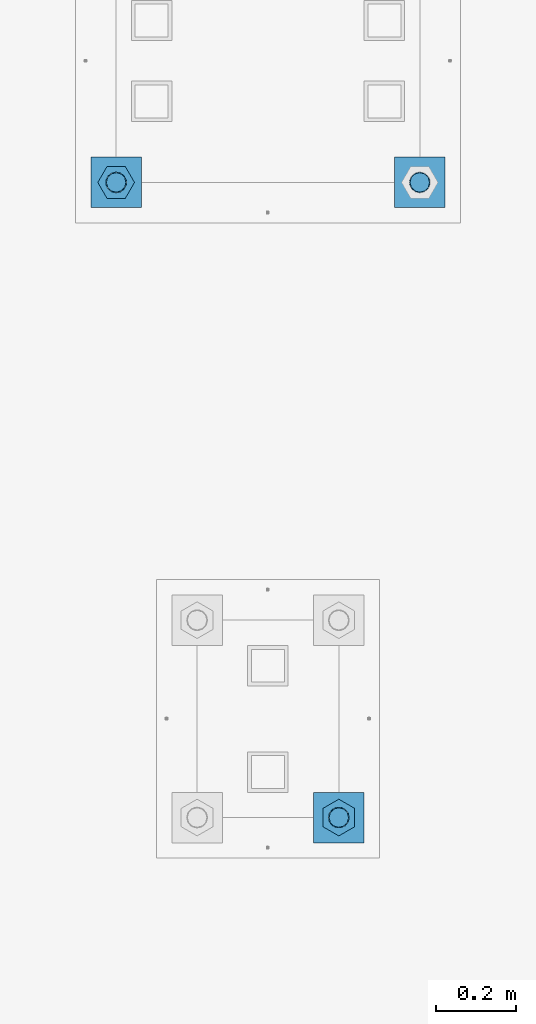
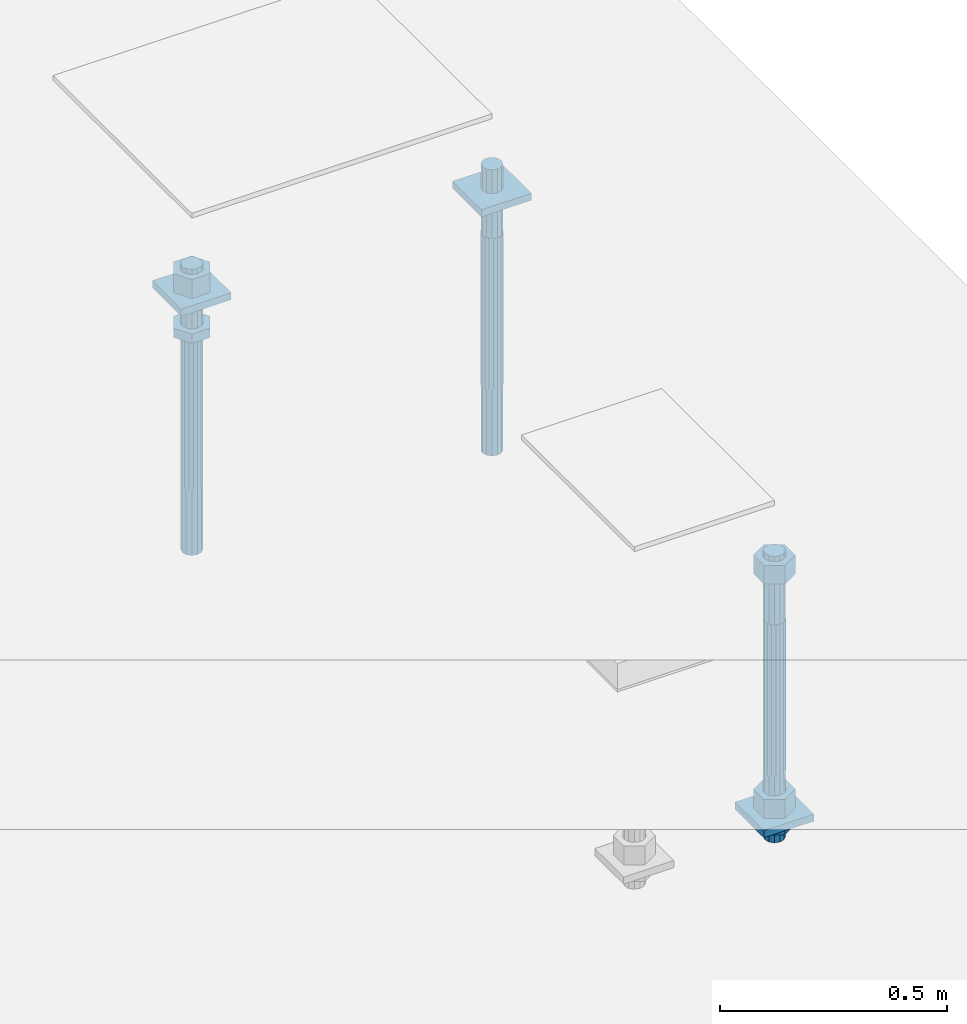
# One storey, part 2631 of 3843: 11 beams, 2 elements without a shape of their own.
"""IFC2X3 building model written with IfcOpenShell, lengths in millimetres."""

from ifc_helpers import new_model, si_unit, frame, origin_with_axes, place, context, subcontext, project, spatial, faceted_brep, material, type_object, element, aggregate, save


model = new_model("IFC2X3")

# Units and contexts
model_context = context("Model", 3, precision=1e-05, world=origin_with_axes())
body_context = subcontext(model_context, "Body", "Model", "MODEL_VIEW")
ifc_project = project(units=[si_unit("LENGTHUNIT", "METRE", prefix="MILLI"), si_unit("AREAUNIT", "SQUARE_METRE"), si_unit("VOLUMEUNIT", "CUBIC_METRE"), si_unit("MASSUNIT", "GRAM", prefix="KILO"), si_unit("TIMEUNIT", "SECOND"), si_unit("PLANEANGLEUNIT", "RADIAN"), si_unit("SOLIDANGLEUNIT", "STERADIAN"), si_unit("THERMODYNAMICTEMPERATUREUNIT", "DEGREE_CELSIUS"), si_unit("LUMINOUSINTENSITYUNIT", "LUMEN")], contexts=[model_context])

# Site, building, storey
site_placement = place(None, origin_with_axes())
site = spatial("IfcSite", under=ifc_project, at=site_placement, CompositionType="ELEMENT")
building_placement = place(site_placement, origin_with_axes())
building = spatial("IfcBuilding", under=site, at=building_placement, Name="Undefined", CompositionType="ELEMENT")
storey_placement = place(building_placement, origin_with_axes())
storey = spatial("IfcBuildingStorey", under=building, at=storey_placement, Name="Undefined", CompositionType="ELEMENT", Elevation=0.0)

# Assembly, beams
assembly_1_placement = place(storey_placement, origin_with_axes())
assembly_1 = element("IfcElementAssembly", 1, at=assembly_1_placement, inside=storey, Name="TEMPLATE", AssemblyPlace="NOTDEFINED", PredefinedType="RIGID_FRAME")
ifc_material_1 = material(Name="STEEL/A572-50")
beam_type_1 = type_object("IfcBeamType", PredefinedType="NOTDEFINED")
beam_1_placement = place(assembly_1_placement, frame((118465.6, 1282.70000152587, 29873.575), z_axis=(1.0, 0.0, 0.0), x_axis=(0.0, 1.0, 0.0)))
beam_1 = element("IfcBeam", 2, at=beam_1_placement, type_object=beam_type_1, material=ifc_material_1, Name="WASHER_PLATE", context=body_context, shape_type="Brep", body=[
    faceted_brep([(0.0, 9.52500000000146, -63.5), (0.0, 9.52500000000146, 63.5), (127.0, 9.52500000000146, 63.5), (127.0, 9.52500000000146, -63.5), (0.0, -9.52500000000146, 63.5), (127.0, -9.52500000000146, 63.5), (0.0, -9.52500000000146, -63.5), (127.0, -9.52500000000146, -63.5)], [[[0, 1, 2, 3]], [[1, 4, 5, 2]], [[4, 6, 7, 5]], [[6, 0, 3, 7]], [[5, 7, 3, 2]], [[6, 4, 1, 0]]]),
])
beam_2_placement = place(assembly_1_placement, frame((119227.6, 1282.70000152587, 29873.575), z_axis=(1.0, 0.0, 0.0), x_axis=(0.0, 1.0, 0.0)))
beam_2 = element("IfcBeam", 3, at=beam_2_placement, type_object=beam_type_1, material=ifc_material_1, Name="WASHER_PLATE", context=body_context, shape_type="Brep", body=[
    faceted_brep([(0.0, 9.52500000000146, -63.5), (0.0, 9.52500000000146, 63.5), (127.0, 9.52500000000146, 63.5), (127.0, 9.52500000000146, -63.5), (0.0, -9.52500000000146, 63.5), (127.0, -9.52500000000146, 63.5), (0.0, -9.52500000000146, -63.5), (127.0, -9.52500000000146, -63.5)], [[[0, 1, 2, 3]], [[1, 4, 5, 2]], [[4, 6, 7, 5]], [[6, 0, 3, 7]], [[5, 7, 3, 2]], [[6, 4, 1, 0]]]),
])

# Assembly, beam
assembly_2_placement = place(storey_placement, origin_with_axes())
assembly_2 = element("IfcElementAssembly", 4, at=assembly_2_placement, inside=storey, Name="TEMPLATE", AssemblyPlace="NOTDEFINED", PredefinedType="RIGID_FRAME")
beam_3_placement = place(assembly_2_placement, frame((118960.900001526, -247.649999999994, 29244.925), z_axis=(0.0, -1.0, 0.0), x_axis=(1.0, 0.0, 0.0)))
beam_3 = element("IfcBeam", 5, at=beam_3_placement, type_object=beam_type_1, material=ifc_material_1, Name="WASHER_PLATE", context=body_context, shape_type="Brep", body=[
    faceted_brep([(0.0, 9.52500000000146, -63.5), (0.0, 9.52500000000146, 63.5), (127.0, 9.52500000000146, 63.5), (127.0, 9.52500000000146, -63.5), (0.0, -9.52500000000146, 63.5), (127.0, -9.52500000000146, 63.5), (0.0, -9.52500000000146, -63.5), (127.0, -9.52500000000146, -63.5)], [[[0, 1, 2, 3]], [[1, 4, 5, 2]], [[4, 6, 7, 5]], [[6, 0, 3, 7]], [[5, 7, 3, 2]], [[6, 4, 1, 0]]]),
])

# Beam
ifc_material_2 = material(Name="STEEL/A36")
beam_type_2 = type_object("IfcBeamType", Name="2_HALF_NUT", PredefinedType="NOTDEFINED")
beam_4_placement = place(assembly_1_placement, frame((118465.6, 1346.20000152587, 29787.85), z_axis=(0.0, 1.0, 0.0), x_axis=(0.0, 0.0, -1.0)))
beam_4 = element("IfcBeam", 6, at=beam_4_placement, type_object=beam_type_2, material=ifc_material_2, Name="NUT", ObjectType="2_HALF_NUT", context=body_context, shape_type="Brep", body=[
    faceted_brep([(0.0, -46.0369987487793, 0.0), (0.0, -23.0184993743896, -39.869213104248), (25.4000000000015, -23.0184993743896, -39.869213104248), (25.4000000000015, -46.0369987487793, 0.0), (0.0, 23.0184993743896, -39.869213104248), (25.4000000000015, 23.0184993743896, -39.869213104248), (0.0, 46.0369987487793, 0.0), (25.4000000000015, 46.0369987487793, 0.0), (0.0, 23.0184993743896, 39.869213104248), (25.4000000000015, 23.0184993743896, 39.869213104248), (0.0, -23.0184993743896, 39.869213104248), (25.4000000000015, -23.0184993743896, 39.869213104248), (0.0, 0.0, 26.1940002441406), (0.0, 11.3650617044477, 23.5999013092805), (25.4000000000015, 11.3650617044477, 23.5999013092805), (25.4000000000015, 0.0, 26.1940002441406), (0.0, 20.4791109456419, 16.3316083006721), (25.4000000000015, 20.4791109456419, 16.3316083006721), (0.0, 25.5370200498292, 5.82867859874386), (25.4000000000015, 25.5370200498292, 5.82867859874386), (0.0, 25.5370200498292, -5.82867859874386), (25.4000000000015, 25.5370200498292, -5.82867859874386), (0.0, 20.4791109456419, -16.3316083006721), (25.4000000000015, 20.4791109456419, -16.3316083006721), (0.0, 11.3650617044477, -23.5999013092805), (25.4000000000015, 11.3650617044477, -23.5999013092805), (0.0, 0.0, -26.1940002441406), (25.4000000000015, 0.0, -26.1940002441406), (0.0, -11.3650617044477, -23.5999013092805), (25.4000000000015, -11.3650617044477, -23.5999013092805), (0.0, -20.4791109456419, -16.3316083006721), (25.4000000000015, -20.4791109456419, -16.3316083006721), (0.0, -25.5370200498292, -5.82867859874386), (25.4000000000015, -25.5370200498292, -5.82867859874386), (0.0, -25.5370200498292, 5.82867859874386), (25.4000000000015, -25.5370200498292, 5.82867859874386), (0.0, -20.4791109456419, 16.3316083006721), (25.4000000000015, -20.4791109456419, 16.3316083006721), (0.0, -11.3650617044477, 23.5999013092805), (25.4000000000015, -11.3650617044477, 23.5999013092805)], [[[0, 1, 2, 3]], [[1, 4, 5, 2]], [[4, 6, 7, 5]], [[6, 8, 9, 7]], [[8, 10, 11, 9]], [[10, 0, 3, 11]], [[12, 13, 14, 15]], [[13, 16, 17, 14]], [[16, 18, 19, 17]], [[18, 20, 21, 19]], [[20, 22, 23, 21]], [[22, 24, 25, 23]], [[24, 26, 27, 25]], [[26, 28, 29, 27]], [[28, 30, 31, 29]], [[30, 32, 33, 31]], [[32, 34, 35, 33]], [[34, 36, 37, 35]], [[36, 38, 39, 37]], [[38, 12, 15, 39]], [[5, 7, 9, 11, 3, 2], [17, 19, 21, 23, 25, 27, 29, 31, 33, 35, 37, 39, 15, 14]], [[10, 8, 6, 4, 1, 0], [38, 36, 34, 32, 30, 28, 26, 24, 22, 20, 18, 16, 13, 12]]]),
])

beam_5_placement = place(assembly_2_placement, frame((119024.400001526, -247.649999999994, 29235.4), z_axis=(1.0, 0.0, 0.0), x_axis=(0.0, 0.0, -1.0)))
beam_5 = element("IfcBeam", 7, at=beam_5_placement, type_object=beam_type_2, material=ifc_material_2, Name="NUT", ObjectType="2_HALF_NUT", context=body_context, shape_type="Brep", body=[
    faceted_brep([(0.0, -46.0369987487793, 0.0), (0.0, -23.0184993743896, -39.869213104248), (25.4000000000015, -23.0184993743896, -39.869213104248), (25.4000000000015, -46.0369987487793, 0.0), (0.0, 23.0184993743896, -39.869213104248), (25.4000000000015, 23.0184993743896, -39.869213104248), (0.0, 46.0369987487793, 0.0), (25.4000000000015, 46.0369987487793, 0.0), (0.0, 23.0184993743896, 39.869213104248), (25.4000000000015, 23.0184993743896, 39.869213104248), (0.0, -23.0184993743896, 39.869213104248), (25.4000000000015, -23.0184993743896, 39.869213104248), (0.0, 0.0, 26.1940002441406), (0.0, 11.3650617044477, 23.5999013092805), (25.4000000000015, 11.3650617044477, 23.5999013092805), (25.4000000000015, 0.0, 26.1940002441406), (0.0, 20.4791109456419, 16.3316083006721), (25.4000000000015, 20.4791109456419, 16.3316083006721), (0.0, 25.5370200498292, 5.82867859874386), (25.4000000000015, 25.5370200498292, 5.82867859874386), (0.0, 25.5370200498292, -5.82867859874386), (25.4000000000015, 25.5370200498292, -5.82867859874386), (0.0, 20.4791109456419, -16.3316083006721), (25.4000000000015, 20.4791109456419, -16.3316083006721), (0.0, 11.3650617044477, -23.5999013092805), (25.4000000000015, 11.3650617044477, -23.5999013092805), (0.0, 0.0, -26.1940002441406), (25.4000000000015, 0.0, -26.1940002441406), (0.0, -11.3650617044477, -23.5999013092805), (25.4000000000015, -11.3650617044477, -23.5999013092805), (0.0, -20.4791109456419, -16.3316083006721), (25.4000000000015, -20.4791109456419, -16.3316083006721), (0.0, -25.5370200498292, -5.82867859874386), (25.4000000000015, -25.5370200498292, -5.82867859874386), (0.0, -25.5370200498292, 5.82867859874386), (25.4000000000015, -25.5370200498292, 5.82867859874386), (0.0, -20.4791109456419, 16.3316083006721), (25.4000000000015, -20.4791109456419, 16.3316083006721), (0.0, -11.3650617044477, 23.5999013092805), (25.4000000000015, -11.3650617044477, 23.5999013092805)], [[[0, 1, 2, 3]], [[1, 4, 5, 2]], [[4, 6, 7, 5]], [[6, 8, 9, 7]], [[8, 10, 11, 9]], [[10, 0, 3, 11]], [[12, 13, 14, 15]], [[13, 16, 17, 14]], [[16, 18, 19, 17]], [[18, 20, 21, 19]], [[20, 22, 23, 21]], [[22, 24, 25, 23]], [[24, 26, 27, 25]], [[26, 28, 29, 27]], [[28, 30, 31, 29]], [[30, 32, 33, 31]], [[32, 34, 35, 33]], [[34, 36, 37, 35]], [[36, 38, 39, 37]], [[38, 12, 15, 39]], [[5, 7, 9, 11, 3, 2], [17, 19, 21, 23, 25, 27, 29, 31, 33, 35, 37, 39, 15, 14]], [[10, 8, 6, 4, 1, 0], [38, 36, 34, 32, 30, 28, 26, 24, 22, 20, 18, 16, 13, 12]]]),
])

beam_type_3 = type_object("IfcBeamType", Name="2_HEAVY_HEX_NUT", PredefinedType="NOTDEFINED")
beam_6_placement = place(assembly_1_placement, frame((118465.6, 1346.20000152587, 29933.9), z_axis=(0.0, 1.0, 0.0), x_axis=(0.0, 0.0, -1.0)))
beam_6 = element("IfcBeam", 8, at=beam_6_placement, type_object=beam_type_3, material=ifc_material_2, Name="NUT", ObjectType="2_HEAVY_HEX_NUT", context=body_context, shape_type="Brep", body=[
    faceted_brep([(0.0, -46.0369987487793, 0.0), (0.0, -23.0184993743896, -39.869213104248), (50.7999999999993, -23.0184993743896, -39.869213104248), (50.7999999999993, -46.0369987487793, 0.0), (0.0, 23.0184993743896, -39.869213104248), (50.7999999999993, 23.0184993743896, -39.869213104248), (0.0, 46.0369987487793, 0.0), (50.7999999999993, 46.0369987487793, 0.0), (0.0, 23.0184993743896, 39.869213104248), (50.7999999999993, 23.0184993743896, 39.869213104248), (0.0, -23.0184993743896, 39.869213104248), (50.7999999999993, -23.0184993743896, 39.869213104248), (0.0, 0.0, 26.1940002441406), (0.0, 11.3650617044477, 23.5999013092805), (50.7999999999993, 11.3650617044477, 23.5999013092805), (50.7999999999993, 0.0, 26.1940002441406), (0.0, 20.4791109456419, 16.3316083006721), (50.7999999999993, 20.4791109456419, 16.3316083006721), (0.0, 25.5370200498292, 5.82867859874386), (50.7999999999993, 25.5370200498292, 5.82867859874386), (0.0, 25.5370200498292, -5.82867859874386), (50.7999999999993, 25.5370200498292, -5.82867859874386), (0.0, 20.4791109456419, -16.3316083006721), (50.7999999999993, 20.4791109456419, -16.3316083006721), (0.0, 11.3650617044477, -23.5999013092805), (50.7999999999993, 11.3650617044477, -23.5999013092805), (0.0, 0.0, -26.1940002441406), (50.7999999999993, 0.0, -26.1940002441406), (0.0, -11.3650617044477, -23.5999013092805), (50.7999999999993, -11.3650617044477, -23.5999013092805), (0.0, -20.4791109456419, -16.3316083006721), (50.7999999999993, -20.4791109456419, -16.3316083006721), (0.0, -25.5370200498292, -5.82867859874386), (50.7999999999993, -25.5370200498292, -5.82867859874386), (0.0, -25.5370200498292, 5.82867859874386), (50.7999999999993, -25.5370200498292, 5.82867859874386), (0.0, -20.4791109456419, 16.3316083006721), (50.7999999999993, -20.4791109456419, 16.3316083006721), (0.0, -11.3650617044477, 23.5999013092805), (50.7999999999993, -11.3650617044477, 23.5999013092805)], [[[0, 1, 2, 3]], [[1, 4, 5, 2]], [[4, 6, 7, 5]], [[6, 8, 9, 7]], [[8, 10, 11, 9]], [[10, 0, 3, 11]], [[12, 13, 14, 15]], [[13, 16, 17, 14]], [[16, 18, 19, 17]], [[18, 20, 21, 19]], [[20, 22, 23, 21]], [[22, 24, 25, 23]], [[24, 26, 27, 25]], [[26, 28, 29, 27]], [[28, 30, 31, 29]], [[30, 32, 33, 31]], [[32, 34, 35, 33]], [[34, 36, 37, 35]], [[36, 38, 39, 37]], [[38, 12, 15, 39]], [[5, 7, 9, 11, 3, 2], [17, 19, 21, 23, 25, 27, 29, 31, 33, 35, 37, 39, 15, 14]], [[10, 8, 6, 4, 1, 0], [38, 36, 34, 32, 30, 28, 26, 24, 22, 20, 18, 16, 13, 12]]]),
])

beam_7_placement = place(assembly_2_placement, frame((119024.400001526, -247.649999999994, 29933.9), z_axis=(1.0, 0.0, 0.0), x_axis=(0.0, 0.0, -1.0)))
beam_7 = element("IfcBeam", 9, at=beam_7_placement, type_object=beam_type_3, material=ifc_material_2, Name="NUT", ObjectType="2_HEAVY_HEX_NUT", context=body_context, shape_type="Brep", body=[
    faceted_brep([(0.0, -46.0369987487793, 0.0), (0.0, -23.0184993743896, -39.869213104248), (50.7999999999993, -23.0184993743896, -39.869213104248), (50.7999999999993, -46.0369987487793, 0.0), (0.0, 23.0184993743896, -39.869213104248), (50.7999999999993, 23.0184993743896, -39.869213104248), (0.0, 46.0369987487793, 0.0), (50.7999999999993, 46.0369987487793, 0.0), (0.0, 23.0184993743896, 39.869213104248), (50.7999999999993, 23.0184993743896, 39.869213104248), (0.0, -23.0184993743896, 39.869213104248), (50.7999999999993, -23.0184993743896, 39.869213104248), (0.0, 0.0, 26.1940002441406), (0.0, 11.3650617044477, 23.5999013092805), (50.7999999999993, 11.3650617044477, 23.5999013092805), (50.7999999999993, 0.0, 26.1940002441406), (0.0, 20.4791109456419, 16.3316083006721), (50.7999999999993, 20.4791109456419, 16.3316083006721), (0.0, 25.5370200498292, 5.82867859874386), (50.7999999999993, 25.5370200498292, 5.82867859874386), (0.0, 25.5370200498292, -5.82867859874386), (50.7999999999993, 25.5370200498292, -5.82867859874386), (0.0, 20.4791109456419, -16.3316083006721), (50.7999999999993, 20.4791109456419, -16.3316083006721), (0.0, 11.3650617044477, -23.5999013092805), (50.7999999999993, 11.3650617044477, -23.5999013092805), (0.0, 0.0, -26.1940002441406), (50.7999999999993, 0.0, -26.1940002441406), (0.0, -11.3650617044477, -23.5999013092805), (50.7999999999993, -11.3650617044477, -23.5999013092805), (0.0, -20.4791109456419, -16.3316083006721), (50.7999999999993, -20.4791109456419, -16.3316083006721), (0.0, -25.5370200498292, -5.82867859874386), (50.7999999999993, -25.5370200498292, -5.82867859874386), (0.0, -25.5370200498292, 5.82867859874386), (50.7999999999993, -25.5370200498292, 5.82867859874386), (0.0, -20.4791109456419, 16.3316083006721), (50.7999999999993, -20.4791109456419, 16.3316083006721), (0.0, -11.3650617044477, 23.5999013092805), (50.7999999999993, -11.3650617044477, 23.5999013092805)], [[[0, 1, 2, 3]], [[1, 4, 5, 2]], [[4, 6, 7, 5]], [[6, 8, 9, 7]], [[8, 10, 11, 9]], [[10, 0, 3, 11]], [[12, 13, 14, 15]], [[13, 16, 17, 14]], [[16, 18, 19, 17]], [[18, 20, 21, 19]], [[20, 22, 23, 21]], [[22, 24, 25, 23]], [[24, 26, 27, 25]], [[26, 28, 29, 27]], [[28, 30, 31, 29]], [[30, 32, 33, 31]], [[32, 34, 35, 33]], [[34, 36, 37, 35]], [[36, 38, 39, 37]], [[38, 12, 15, 39]], [[5, 7, 9, 11, 3, 2], [17, 19, 21, 23, 25, 27, 29, 31, 33, 35, 37, 39, 15, 14]], [[10, 8, 6, 4, 1, 0], [38, 36, 34, 32, 30, 28, 26, 24, 22, 20, 18, 16, 13, 12]]]),
])

beam_8_placement = place(assembly_2_placement, frame((119024.400001526, -247.649999999994, 29305.25), z_axis=(1.0, 0.0, 0.0), x_axis=(0.0, 0.0, -1.0)))
beam_8 = element("IfcBeam", 10, at=beam_8_placement, type_object=beam_type_3, material=ifc_material_2, Name="NUT", ObjectType="2_HEAVY_HEX_NUT", context=body_context, shape_type="Brep", body=[
    faceted_brep([(0.0, -46.0369987487793, 0.0), (0.0, -23.0184993743896, -39.869213104248), (50.7999999999993, -23.0184993743896, -39.869213104248), (50.7999999999993, -46.0369987487793, 0.0), (0.0, 23.0184993743896, -39.869213104248), (50.7999999999993, 23.0184993743896, -39.869213104248), (0.0, 46.0369987487793, 0.0), (50.7999999999993, 46.0369987487793, 0.0), (0.0, 23.0184993743896, 39.869213104248), (50.7999999999993, 23.0184993743896, 39.869213104248), (0.0, -23.0184993743896, 39.869213104248), (50.7999999999993, -23.0184993743896, 39.869213104248), (0.0, 0.0, 26.1940002441406), (0.0, 11.3650617044477, 23.5999013092805), (50.7999999999993, 11.3650617044477, 23.5999013092805), (50.7999999999993, 0.0, 26.1940002441406), (0.0, 20.4791109456419, 16.3316083006721), (50.7999999999993, 20.4791109456419, 16.3316083006721), (0.0, 25.5370200498292, 5.82867859874386), (50.7999999999993, 25.5370200498292, 5.82867859874386), (0.0, 25.5370200498292, -5.82867859874386), (50.7999999999993, 25.5370200498292, -5.82867859874386), (0.0, 20.4791109456419, -16.3316083006721), (50.7999999999993, 20.4791109456419, -16.3316083006721), (0.0, 11.3650617044477, -23.5999013092805), (50.7999999999993, 11.3650617044477, -23.5999013092805), (0.0, 0.0, -26.1940002441406), (50.7999999999993, 0.0, -26.1940002441406), (0.0, -11.3650617044477, -23.5999013092805), (50.7999999999993, -11.3650617044477, -23.5999013092805), (0.0, -20.4791109456419, -16.3316083006721), (50.7999999999993, -20.4791109456419, -16.3316083006721), (0.0, -25.5370200498292, -5.82867859874386), (50.7999999999993, -25.5370200498292, -5.82867859874386), (0.0, -25.5370200498292, 5.82867859874386), (50.7999999999993, -25.5370200498292, 5.82867859874386), (0.0, -20.4791109456419, 16.3316083006721), (50.7999999999993, -20.4791109456419, 16.3316083006721), (0.0, -11.3650617044477, 23.5999013092805), (50.7999999999993, -11.3650617044477, 23.5999013092805)], [[[0, 1, 2, 3]], [[1, 4, 5, 2]], [[4, 6, 7, 5]], [[6, 8, 9, 7]], [[8, 10, 11, 9]], [[10, 0, 3, 11]], [[12, 13, 14, 15]], [[13, 16, 17, 14]], [[16, 18, 19, 17]], [[18, 20, 21, 19]], [[20, 22, 23, 21]], [[22, 24, 25, 23]], [[24, 26, 27, 25]], [[26, 28, 29, 27]], [[28, 30, 31, 29]], [[30, 32, 33, 31]], [[32, 34, 35, 33]], [[34, 36, 37, 35]], [[36, 38, 39, 37]], [[38, 12, 15, 39]], [[5, 7, 9, 11, 3, 2], [17, 19, 21, 23, 25, 27, 29, 31, 33, 35, 37, 39, 15, 14]], [[10, 8, 6, 4, 1, 0], [38, 36, 34, 32, 30, 28, 26, 24, 22, 20, 18, 16, 13, 12]]]),
])

ifc_material_3 = material()
beam_type_4 = type_object("IfcBeamType", PredefinedType="NOTDEFINED")
beam_9_placement = place(assembly_1_placement, frame((118465.600001526, 1346.19999999998, 29762.45), z_axis=(1.0, 0.0, 0.0), x_axis=(0.0, 0.0, -1.0)))
beam_9 = element("IfcBeam", 11, at=beam_9_placement, type_object=beam_type_4, material=ifc_material_3, Name="ANCHOR_ROD", context=body_context, shape_type="Brep", body=[
    faceted_brep([(0.0, -23.4665401257807, -9.72015918207035), (0.0, -17.9605122421344, -17.9605122421417), (406.399999999998, -17.9605122421344, -17.9605122421417), (406.399999999998, -23.4665401257807, -9.72015918207035), (0.0, -9.72015918207762, -23.466540125788), (406.399999999998, -9.72015918207762, -23.466540125788), (0.0, 0.0, -25.4000000000015), (406.399999999998, 0.0, -25.4000000000015), (0.0, 9.72015918207762, -23.466540125788), (406.399999999998, 9.72015918207762, -23.466540125788), (0.0, 17.9605122421344, -17.9605122421417), (406.399999999998, 17.9605122421344, -17.9605122421417), (0.0, 23.4665401257807, -9.72015918207035), (406.399999999998, 23.4665401257807, -9.72015918207035), (0.0, 25.3999996185303, 0.0), (406.399999999998, 25.3999999999942, 0.0), (0.0, 23.4665401257807, 9.72015918207035), (406.399999999998, 23.4665401257807, 9.72015918207035), (0.0, 17.9605122421344, 17.9605122421417), (406.399999999998, 17.9605122421344, 17.9605122421417), (0.0, 9.72015918207762, 23.466540125788), (406.399999999998, 9.72015918207762, 23.466540125788), (0.0, 0.0, 25.4000000000015), (406.399999999998, 0.0, 25.4000000000015), (0.0, -9.72015918207762, 23.466540125788), (406.399999999998, -9.72015918207762, 23.466540125788), (0.0, -17.9605122421344, 17.9605122421417), (406.399999999998, -17.9605122421344, 17.9605122421417), (0.0, -23.4665401257807, 9.72015918207035), (406.399999999998, -23.4665401257807, 9.72015918207035), (0.0, -25.3999996185303, 0.0), (406.399999999998, -25.3999999999942, 0.0), (584.200000000001, -12.2499999999854, -21.2176223927163), (584.200000000001, 1.45519152283669e-11, -24.5), (584.200000000001, 12.2500000000146, -21.2176223927163), (584.200000000001, 21.2176223927381, -12.25), (584.200000000001, 24.5000000000146, 0.0), (584.200000000001, 21.2176223927381, 12.25), (584.200000000001, 12.2500000000146, 21.2176223927163), (584.200000000001, 1.45519152283669e-11, 24.5), (584.200000000001, -12.2499999999854, 21.2176223927163), (584.200000000001, -21.217622392709, 12.25), (584.200000000001, -24.4999999999854, 0.0), (584.200000000001, -21.217622392709, -12.25), (406.399999999998, -24.4999999999854, 0.0), (406.399999999998, -21.217622392709, -12.25), (406.399999999998, -12.2499999999854, -21.2176223927163), (406.399999999998, 1.45519152283669e-11, -24.5), (406.399999999998, 12.2500000000146, -21.2176223927163), (406.399999999998, 21.2176223927381, -12.25), (406.399999999998, 24.5000000000146, 0.0), (406.399999999998, 21.2176223927381, 12.25), (406.399999999998, 12.2500000000146, 21.2176223927163), (406.399999999998, 1.45519152283669e-11, 24.5), (406.399999999998, -12.2499999999854, 21.2176223927163), (406.399999999998, -21.217622392709, 12.25), (0.0, 12.2500000000146, 21.2176223927163), (0.0, 1.45519152283669e-11, 24.5), (0.0, -12.2499999999854, 21.2176223927163), (0.0, -21.217622392709, 12.25), (0.0, -24.4999999999854, 0.0), (0.0, -21.217622392709, -12.25), (0.0, -12.2499999999854, -21.2176223927163), (0.0, 1.45519152283669e-11, -24.5), (0.0, 12.2500000000146, -21.2176223927163), (0.0, 21.2176223927381, -12.25), (0.0, 24.5000000000146, 0.0), (0.0, 21.2176223927381, 12.25), (-184.150000000001, -21.217622392709, 12.25), (-184.150000000001, -12.2499999999854, 21.2176223927163), (-184.150000000001, 1.45519152283669e-11, 24.5), (-184.150000000001, 12.2500000000146, 21.2176223927163), (-184.150000000001, 21.2176223927381, 12.25), (-184.150000000001, 24.5000000000146, 0.0), (-184.150000000001, 21.2176223927381, -12.25), (-184.150000000001, 12.2500000000146, -21.2176223927163), (-184.150000000001, 1.45519152283669e-11, -24.5), (-184.150000000001, -12.2499999999854, -21.2176223927163), (-184.150000000001, -21.217622392709, -12.25), (-184.150000000001, -24.4999999999854, 0.0)], [[[0, 1, 2, 3]], [[1, 4, 5, 2]], [[4, 6, 7, 5]], [[6, 8, 9, 7]], [[8, 10, 11, 9]], [[10, 12, 13, 11]], [[12, 14, 15, 13]], [[14, 16, 17, 15]], [[16, 18, 19, 17]], [[18, 20, 21, 19]], [[20, 22, 23, 21]], [[22, 24, 25, 23]], [[24, 26, 27, 25]], [[26, 28, 29, 27]], [[28, 30, 31, 29]], [[32, 33, 34, 35, 36, 37, 38, 39, 40, 41, 42, 43]], [[43, 42, 44, 45]], [[32, 43, 45, 46]], [[33, 32, 46, 47]], [[34, 33, 47, 48]], [[35, 34, 48, 49]], [[36, 35, 49, 50]], [[37, 36, 50, 51]], [[38, 37, 51, 52]], [[39, 38, 52, 53]], [[40, 39, 53, 54]], [[41, 40, 54, 55]], [[42, 41, 55, 44]], [[2, 5, 7, 9, 11, 13, 15, 17, 19, 21, 23, 25, 27, 29, 31, 3], [54, 53, 52, 51, 50, 49, 48, 47, 46, 45, 44, 55]], [[30, 0, 3, 31]], [[28, 26, 24, 22, 20, 18, 16, 14, 12, 10, 8, 6, 4, 1, 0, 30], [56, 57, 58, 59, 60, 61, 62, 63, 64, 65, 66, 67]], [[68, 69, 70, 71, 72, 73, 74, 75, 76, 77, 78, 79]], [[71, 70, 57, 56]], [[72, 71, 56, 67]], [[73, 72, 67, 66]], [[74, 73, 66, 65]], [[75, 74, 65, 64]], [[76, 75, 64, 63]], [[77, 76, 63, 62]], [[78, 77, 62, 61]], [[79, 78, 61, 60]], [[68, 79, 60, 59]], [[69, 68, 59, 58]], [[70, 69, 58, 57]]]),
])

beam_10_placement = place(assembly_1_placement, frame((119227.600001526, 1346.19999999998, 29762.45), z_axis=(1.0, 0.0, 0.0), x_axis=(0.0, 0.0, -1.0)))
beam_10 = element("IfcBeam", 12, at=beam_10_placement, type_object=beam_type_4, material=ifc_material_3, Name="ANCHOR_ROD", context=body_context, shape_type="Brep", body=[
    faceted_brep([(0.0, -23.4665401257807, -9.72015918207035), (0.0, -17.9605122421344, -17.9605122421417), (406.399999999998, -17.9605122421344, -17.9605122421417), (406.399999999998, -23.4665401257807, -9.72015918207035), (0.0, -9.72015918207762, -23.466540125788), (406.399999999998, -9.72015918207762, -23.466540125788), (0.0, 0.0, -25.4000000000015), (406.399999999998, 0.0, -25.4000000000015), (0.0, 9.72015918207762, -23.466540125788), (406.399999999998, 9.72015918207762, -23.466540125788), (0.0, 17.9605122421344, -17.9605122421417), (406.399999999998, 17.9605122421344, -17.9605122421417), (0.0, 23.4665401257807, -9.72015918207035), (406.399999999998, 23.4665401257807, -9.72015918207035), (0.0, 25.3999996185303, 0.0), (406.399999999998, 25.3999999999942, 0.0), (0.0, 23.4665401257807, 9.72015918207035), (406.399999999998, 23.4665401257807, 9.72015918207035), (0.0, 17.9605122421344, 17.9605122421417), (406.399999999998, 17.9605122421344, 17.9605122421417), (0.0, 9.72015918207762, 23.466540125788), (406.399999999998, 9.72015918207762, 23.466540125788), (0.0, 0.0, 25.4000000000015), (406.399999999998, 0.0, 25.4000000000015), (0.0, -9.72015918207762, 23.466540125788), (406.399999999998, -9.72015918207762, 23.466540125788), (0.0, -17.9605122421344, 17.9605122421417), (406.399999999998, -17.9605122421344, 17.9605122421417), (0.0, -23.4665401257807, 9.72015918207035), (406.399999999998, -23.4665401257807, 9.72015918207035), (0.0, -25.3999996185303, 0.0), (406.399999999998, -25.3999999999942, 0.0), (584.200000000001, -12.2499999999854, -21.2176223927163), (584.200000000001, 1.45519152283669e-11, -24.5), (584.200000000001, 12.2500000000146, -21.2176223927163), (584.200000000001, 21.2176223927381, -12.25), (584.200000000001, 24.5000000000146, 0.0), (584.200000000001, 21.2176223927381, 12.25), (584.200000000001, 12.2500000000146, 21.2176223927163), (584.200000000001, 1.45519152283669e-11, 24.5), (584.200000000001, -12.2499999999854, 21.2176223927163), (584.200000000001, -21.217622392709, 12.25), (584.200000000001, -24.4999999999854, 0.0), (584.200000000001, -21.217622392709, -12.25), (406.399999999998, -24.4999999999854, 0.0), (406.399999999998, -21.217622392709, -12.25), (406.399999999998, -12.2499999999854, -21.2176223927163), (406.399999999998, 1.45519152283669e-11, -24.5), (406.399999999998, 12.2500000000146, -21.2176223927163), (406.399999999998, 21.2176223927381, -12.25), (406.399999999998, 24.5000000000146, 0.0), (406.399999999998, 21.2176223927381, 12.25), (406.399999999998, 12.2500000000146, 21.2176223927163), (406.399999999998, 1.45519152283669e-11, 24.5), (406.399999999998, -12.2499999999854, 21.2176223927163), (406.399999999998, -21.217622392709, 12.25), (0.0, 12.2500000000146, 21.2176223927163), (0.0, 1.45519152283669e-11, 24.5), (0.0, -12.2499999999854, 21.2176223927163), (0.0, -21.217622392709, 12.25), (0.0, -24.4999999999854, 0.0), (0.0, -21.217622392709, -12.25), (0.0, -12.2499999999854, -21.2176223927163), (0.0, 1.45519152283669e-11, -24.5), (0.0, 12.2500000000146, -21.2176223927163), (0.0, 21.2176223927381, -12.25), (0.0, 24.5000000000146, 0.0), (0.0, 21.2176223927381, 12.25), (-184.150000000001, -21.217622392709, 12.25), (-184.150000000001, -12.2499999999854, 21.2176223927163), (-184.150000000001, 1.45519152283669e-11, 24.5), (-184.150000000001, 12.2500000000146, 21.2176223927163), (-184.150000000001, 21.2176223927381, 12.25), (-184.150000000001, 24.5000000000146, 0.0), (-184.150000000001, 21.2176223927381, -12.25), (-184.150000000001, 12.2500000000146, -21.2176223927163), (-184.150000000001, 1.45519152283669e-11, -24.5), (-184.150000000001, -12.2499999999854, -21.2176223927163), (-184.150000000001, -21.217622392709, -12.25), (-184.150000000001, -24.4999999999854, 0.0)], [[[0, 1, 2, 3]], [[1, 4, 5, 2]], [[4, 6, 7, 5]], [[6, 8, 9, 7]], [[8, 10, 11, 9]], [[10, 12, 13, 11]], [[12, 14, 15, 13]], [[14, 16, 17, 15]], [[16, 18, 19, 17]], [[18, 20, 21, 19]], [[20, 22, 23, 21]], [[22, 24, 25, 23]], [[24, 26, 27, 25]], [[26, 28, 29, 27]], [[28, 30, 31, 29]], [[32, 33, 34, 35, 36, 37, 38, 39, 40, 41, 42, 43]], [[43, 42, 44, 45]], [[32, 43, 45, 46]], [[33, 32, 46, 47]], [[34, 33, 47, 48]], [[35, 34, 48, 49]], [[36, 35, 49, 50]], [[37, 36, 50, 51]], [[38, 37, 51, 52]], [[39, 38, 52, 53]], [[40, 39, 53, 54]], [[41, 40, 54, 55]], [[42, 41, 55, 44]], [[2, 5, 7, 9, 11, 13, 15, 17, 19, 21, 23, 25, 27, 29, 31, 3], [54, 53, 52, 51, 50, 49, 48, 47, 46, 45, 44, 55]], [[30, 0, 3, 31]], [[28, 26, 24, 22, 20, 18, 16, 14, 12, 10, 8, 6, 4, 1, 0, 30], [56, 57, 58, 59, 60, 61, 62, 63, 64, 65, 66, 67]], [[68, 69, 70, 71, 72, 73, 74, 75, 76, 77, 78, 79]], [[71, 70, 57, 56]], [[72, 71, 56, 67]], [[73, 72, 67, 66]], [[74, 73, 66, 65]], [[75, 74, 65, 64]], [[76, 75, 64, 63]], [[77, 76, 63, 62]], [[78, 77, 62, 61]], [[79, 78, 61, 60]], [[68, 79, 60, 59]], [[69, 68, 59, 58]], [[70, 69, 58, 57]]]),
])

aggregate(assembly_1, [beam_9, beam_10, beam_1, beam_2, beam_4, beam_6])

beam_11_placement = place(assembly_2_placement, frame((119024.400001526, -247.649999999994, 29762.45), z_axis=(1.0, 0.0, 0.0), x_axis=(0.0, 0.0, -1.0)))
beam_11 = element("IfcBeam", 13, at=beam_11_placement, type_object=beam_type_4, material=ifc_material_3, Name="ANCHOR_ROD", context=body_context, shape_type="Brep", body=[
    faceted_brep([(-184.150000000001, -21.217622392709, 12.25), (-184.150000000001, -12.2499999999854, 21.2176223927163), (-184.150000000001, 1.45519152283669e-11, 24.5), (-184.150000000001, 12.2500000000146, 21.2176223927163), (-184.150000000001, 21.2176223927381, 12.25), (-184.150000000001, 24.5000000000146, 0.0), (-184.150000000001, 21.2176223927381, -12.25), (-184.150000000001, 12.2500000000146, -21.2176223927163), (-184.150000000001, 1.45519152283669e-11, -24.5), (-184.150000000001, -12.2499999999854, -21.2176223927163), (-184.150000000001, -21.217622392709, -12.25), (-184.150000000001, -24.4999999999854, 0.0), (0.0, 24.5000000000146, 0.0), (0.0, 21.2176223927381, -12.25), (0.0, 12.2500000000146, -21.2176223927163), (0.0, 1.45519152283669e-11, -24.5), (0.0, -12.2499999999854, -21.2176223927163), (0.0, -21.217622392709, -12.25), (0.0, -24.4999999999854, 0.0), (0.0, -21.217622392709, 12.25), (0.0, -12.2499999999854, 21.2176223927163), (0.0, 1.45519152283669e-11, 24.5), (0.0, 12.2500000000146, 21.2176223927163), (0.0, 21.2176223927381, 12.25), (0.0, -23.4665401257807, 9.72015918207035), (0.0, -17.9605122421344, 17.9605122421417), (0.0, -9.72015918207762, 23.466540125788), (0.0, 0.0, 25.4000000000015), (0.0, 9.72015918207762, 23.466540125788), (0.0, 17.9605122421344, 17.9605122421417), (0.0, 23.4665401257807, 9.72015918207035), (0.0, 25.3999996185303, 0.0), (0.0, 23.4665401257807, -9.72015918207035), (0.0, 17.9605122421344, -17.9605122421417), (0.0, 9.72015918207762, -23.466540125788), (0.0, 0.0, -25.4000000000015), (0.0, -9.72015918207762, -23.466540125788), (0.0, -17.9605122421344, -17.9605122421417), (0.0, -23.4665401257807, -9.72015918207035), (0.0, -25.3999996185303, 0.0), (406.399999999998, -25.3999999999942, 0.0), (406.399999999998, -23.4665401257807, 9.72015918207035), (406.399999999998, -17.9605122421344, 17.9605122421417), (406.399999999998, -9.72015918207762, 23.466540125788), (406.399999999998, 0.0, 25.4000000000015), (406.399999999998, 9.72015918207762, 23.466540125788), (406.399999999998, 17.9605122421344, 17.9605122421417), (406.399999999998, 23.4665401257807, 9.72015918207035), (406.399999999998, 25.3999999999942, 0.0), (406.399999999998, 23.4665401257807, -9.72015918207035), (406.399999999998, 17.9605122421344, -17.9605122421417), (406.399999999998, 9.72015918207762, -23.466540125788), (406.399999999998, 0.0, -25.4000000000015), (406.399999999998, -9.72015918207762, -23.466540125788), (406.399999999998, -17.9605122421344, -17.9605122421417), (406.399999999998, -23.4665401257807, -9.72015918207035), (406.399999999998, -12.2499999999854, 21.2176223927163), (406.399999999998, 1.45519152283669e-11, 24.5), (406.399999999998, 12.2500000000146, 21.2176223927163), (406.399999999998, 21.2176223927381, 12.25), (406.399999999998, 24.5000000000146, 0.0), (406.399999999998, 21.2176223927381, -12.25), (406.399999999998, 12.2500000000146, -21.2176223927163), (406.399999999998, 1.45519152283669e-11, -24.5), (406.399999999998, -12.2499999999854, -21.2176223927163), (406.399999999998, -21.217622392709, -12.25), (406.399999999998, -24.4999999999854, 0.0), (406.399999999998, -21.217622392709, 12.25), (584.200000000001, -12.2499999999854, -21.2176223927163), (584.200000000001, 1.45519152283669e-11, -24.5), (584.200000000001, 12.2500000000146, -21.2176223927163), (584.200000000001, 21.2176223927381, -12.25), (584.200000000001, 24.5000000000146, 0.0), (584.200000000001, 21.2176223927381, 12.25), (584.200000000001, 12.2500000000146, 21.2176223927163), (584.200000000001, 1.45519152283669e-11, 24.5), (584.200000000001, -12.2499999999854, 21.2176223927163), (584.200000000001, -21.217622392709, 12.25), (584.200000000001, -24.4999999999854, 0.0), (584.200000000001, -21.217622392709, -12.25)], [[[0, 1, 2, 3, 4, 5, 6, 7, 8, 9, 10, 11]], [[6, 5, 12, 13]], [[7, 6, 13, 14]], [[8, 7, 14, 15]], [[9, 8, 15, 16]], [[10, 9, 16, 17]], [[11, 10, 17, 18]], [[0, 11, 18, 19]], [[1, 0, 19, 20]], [[2, 1, 20, 21]], [[3, 2, 21, 22]], [[4, 3, 22, 23]], [[5, 4, 23, 12]], [[24, 25, 26, 27, 28, 29, 30, 31, 32, 33, 34, 35, 36, 37, 38, 39], [22, 21, 20, 19, 18, 17, 16, 15, 14, 13, 12, 23]], [[24, 39, 40, 41]], [[25, 24, 41, 42]], [[26, 25, 42, 43]], [[27, 26, 43, 44]], [[28, 27, 44, 45]], [[29, 28, 45, 46]], [[30, 29, 46, 47]], [[31, 30, 47, 48]], [[32, 31, 48, 49]], [[33, 32, 49, 50]], [[34, 33, 50, 51]], [[35, 34, 51, 52]], [[36, 35, 52, 53]], [[37, 36, 53, 54]], [[38, 37, 54, 55]], [[39, 38, 55, 40]], [[54, 53, 52, 51, 50, 49, 48, 47, 46, 45, 44, 43, 42, 41, 40, 55], [56, 57, 58, 59, 60, 61, 62, 63, 64, 65, 66, 67]], [[68, 69, 70, 71, 72, 73, 74, 75, 76, 77, 78, 79]], [[76, 75, 57, 56]], [[77, 76, 56, 67]], [[78, 77, 67, 66]], [[79, 78, 66, 65]], [[68, 79, 65, 64]], [[69, 68, 64, 63]], [[70, 69, 63, 62]], [[71, 70, 62, 61]], [[72, 71, 61, 60]], [[73, 72, 60, 59]], [[74, 73, 59, 58]], [[75, 74, 58, 57]]]),
])

aggregate(assembly_2, [beam_7, beam_8, beam_5, beam_3, beam_11])

save(model, "model.ifc")
